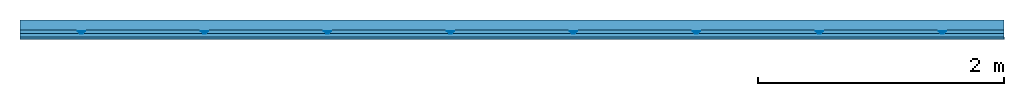
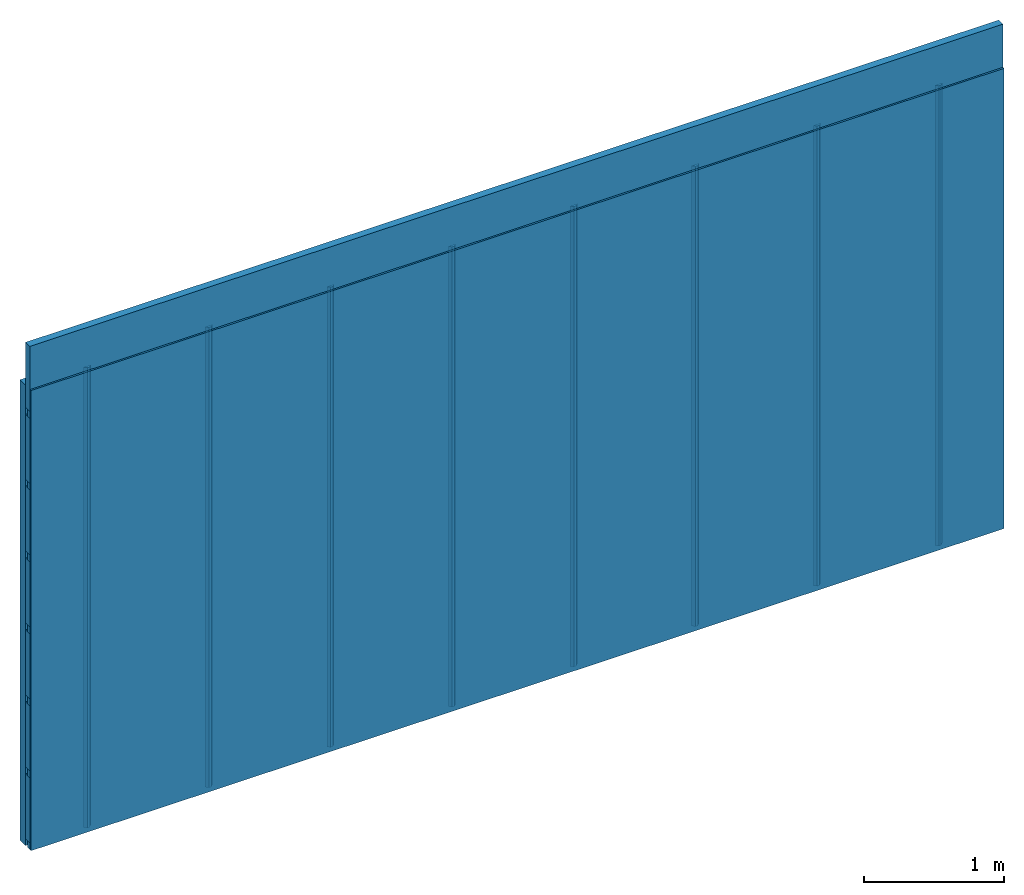
# One storey: 4 members, 1 plate, 1 element without a shape of its own.
"""IFC4 building model written with IfcOpenShell, lengths in metres."""

import ifcopenshell
import ifcopenshell.guid

model = None  # the IFC model being written
_history = None  # IfcOwnerHistory: only IFC2X3 demands one
_inside = {}  # id of a spatial element -> (the spatial element, [elements in it])
_under = {}  # id of a project, library or spatial element -> (it, [spatial elements below it])
_declared = {}  # id of a project -> (the project, [libraries it declares])
_typed = {}  # id of a type object -> (the type object, [elements of that type])
_made_of = {}  # id of a material, layer set ... -> (it, [elements and type objects made of it])


def new_model(schema):
    """Start an empty IFC model of exactly this schema.

    Asked for "IFC4X3", IfcOpenShell would pick the latest addendum, in which some entities
    have other attributes; the version numbers below select the first issue.
    IFC2X3 requires an IfcOwnerHistory on every rooted entity: one is made here for all.
    """
    global model, _history
    if schema == "IFC4X3":
        model = ifcopenshell.file(schema_version=(4, 3, 0, 0))
    else:
        model = ifcopenshell.file(schema=schema)
    _inside.clear()
    _under.clear()
    _declared.clear()
    _typed.clear()
    _made_of.clear()
    _history = None
    if model.schema == "IFC2X3":
        org = make("IfcOrganization", Name="unknown")
        user = make(
            "IfcPersonAndOrganization",
            ThePerson=make("IfcPerson", FamilyName="unknown"),
            TheOrganization=org,
        )
        app = make(
            "IfcApplication",
            ApplicationDeveloper=org,
            Version="unknown",
            ApplicationFullName="unknown",
            ApplicationIdentifier="unknown",
        )
        _history = make(
            "IfcOwnerHistory",
            OwningUser=user,
            OwningApplication=app,
            ChangeAction="ADDED",
            CreationDate=0,
        )
    return model


def make(cls, **values):
    """One entity of the class cls with the attributes given. An attribute that is None is left unset."""
    return model.create_entity(
        cls, **{name: value for name, value in values.items() if value is not None}
    )


def rooted(cls, **values):
    """An entity with a GlobalId (a new one), such as an element, a storey or a relation."""
    return make(cls, GlobalId=ifcopenshell.guid.new(), OwnerHistory=_history, **values)


def si_unit(unit_type, name, prefix=None):
    """IfcSIUnit, for example si_unit("LENGTHUNIT", "METRE", prefix="MILLI")."""
    return make("IfcSIUnit", UnitType=unit_type, Prefix=prefix, Name=name)


def derived_unit(unit_type, elements):
    """IfcDerivedUnit: a product of units, each with its exponent."""
    return make(
        "IfcDerivedUnit",
        Elements=[
            make("IfcDerivedUnitElement", Unit=unit, Exponent=power)
            for unit, power in elements
        ],
        UnitType=unit_type,
    )


def assignment(units):
    """IfcUnitAssignment: the units of a project."""
    return None if units is None else make("IfcUnitAssignment", Units=units)


def point(xyz):
    """IfcCartesianPoint."""
    return None if xyz is None else make("IfcCartesianPoint", Coordinates=xyz)


def direction(xyz):
    """IfcDirection."""
    return None if xyz is None else make("IfcDirection", DirectionRatios=xyz)


def frame(location, z_axis=None, x_axis=None):
    """IfcAxis2Placement3D, a coordinate frame: its origin and axes. An axis left out is left unset."""
    return make(
        "IfcAxis2Placement3D",
        Location=point(location),
        Axis=direction(z_axis),
        RefDirection=direction(x_axis),
    )


def frame_2d(location, x_axis=None):
    """IfcAxis2Placement2D, a coordinate frame in the plane: its origin and x axis."""
    return make(
        "IfcAxis2Placement2D", Location=point(location), RefDirection=direction(x_axis)
    )


def origin():
    """The frame at (0, 0, 0) with its axes left unset."""
    return frame((0.0, 0.0, 0.0))


def place(relative_to, where):
    """IfcLocalPlacement: puts the frame where relative to a parent placement (None: the world)."""
    return make(
        "IfcLocalPlacement", PlacementRelTo=relative_to, RelativePlacement=where
    )


def context(
    kind, dimensions, precision=None, world=None, true_north=None, identifier=None
):
    """IfcGeometricRepresentationContext, for example the 3D "Model" context."""
    return make(
        "IfcGeometricRepresentationContext",
        ContextIdentifier=identifier,
        ContextType=kind,
        CoordinateSpaceDimension=dimensions,
        Precision=precision,
        WorldCoordinateSystem=world,
        TrueNorth=true_north,
    )


def project(units=None, contexts=None):
    """IfcProject with its units and contexts."""
    return rooted(
        "IfcProject",
        Name="project",
        RepresentationContexts=contexts,
        UnitsInContext=assignment(units),
    )


def spatial(cls, under=None, at=None, **own):
    """A site, building, storey or space (cls), placed at a placement, below another one or the project."""
    s = rooted(cls, ObjectPlacement=at, **own)
    if under is not None:
        _under.setdefault(under.id(), (under, []))[1].append(s)
    return s


def polyline(points):
    """IfcPolyline through the points."""
    return make("IfcPolyline", Points=[point(p) for p in points])


def profile(cls, at=None, kind="AREA", **sizes):
    """A parametric profile (cls). Its sizes go by their IFC names, for example OverallWidth=200.0."""
    return make(cls, ProfileType=kind, Position=at, **sizes)


def rectangle(**sizes):
    """IfcRectangleProfileDef."""
    return profile("IfcRectangleProfileDef", **sizes)


def outline(outer, holes=None, kind="AREA"):
    """IfcArbitraryClosedProfileDef: a profile drawn as a closed curve; with holes, ...WithVoids."""
    if holes is None:
        return make("IfcArbitraryClosedProfileDef", ProfileType=kind, OuterCurve=outer)
    return make(
        "IfcArbitraryProfileDefWithVoids",
        ProfileType=kind,
        OuterCurve=outer,
        InnerCurves=holes,
    )


def extrude(swept, where, along, depth):
    """IfcExtrudedAreaSolid: the profile swept, set in the frame where, extruded along a direction by depth."""
    return make(
        "IfcExtrudedAreaSolid",
        SweptArea=swept,
        Position=where,
        ExtrudedDirection=direction(along),
        Depth=depth,
    )


def shape(context_of_items, identifier, shape_type, items):
    """IfcShapeRepresentation: the items that make up one representation, for example the "Body"."""
    return make(
        "IfcShapeRepresentation",
        ContextOfItems=context_of_items,
        RepresentationIdentifier=identifier,
        RepresentationType=shape_type,
        Items=items,
    )


def material(Name=None, Category=None):
    """IfcMaterial."""
    return make("IfcMaterial", Name=Name, Category=Category)


def layer(
    of_material, thickness, ventilated=None, Name=None, Category=None, Priority=None
):
    """IfcMaterialLayer: one layer of a wall or slab, of a material (None: an air gap)."""
    return make(
        "IfcMaterialLayer",
        Material=of_material,
        LayerThickness=thickness,
        IsVentilated=ventilated,
        Name=Name,
        Category=Category,
        Priority=Priority,
    )


def layer_set(layers, Name=None):
    """IfcMaterialLayerSet."""
    return make("IfcMaterialLayerSet", MaterialLayers=layers, LayerSetName=Name)


def made_of(thing, what):
    """Note that an element or type object is made of a material, layer set ...; save() writes the relation."""
    if what is not None:
        _made_of.setdefault(what.id(), (what, []))[1].append(thing)
    return thing


def type_object(cls, material=None, **own):
    """A type object (cls), such as IfcWallType, which elements share."""
    return made_of(rooted(cls, **own), material)


def element(
    cls,
    number,
    at=None,
    inside=None,
    cuts=None,
    type_object=None,
    material=None,
    context=None,
    identifier="Body",
    shape_type=None,
    held_by="IfcProductDefinitionShape",
    body=None,
    shapes=None,
    **own,
):
    """One element of the class cls, such as IfcWall. Its Tag is "e" and its number.

    at: its placement. inside: the storey or other place that contains it. cuts: it is an
    opening in that element (IfcRelVoidsElement). A single representation is given by context,
    identifier, shape_type and body (its items); several are given by shapes. held_by: the class
    of the entity that holds the representations. save() writes the other relations.
    """
    e = rooted(cls, Tag="e%d" % number, ObjectPlacement=at, **own)
    if body is not None:
        shapes = [shape(context, identifier, shape_type, body)]
    if shapes is not None:
        e.Representation = make(held_by, Representations=shapes)
    if inside is not None:
        _inside.setdefault(inside.id(), (inside, []))[1].append(e)
    if cuts is not None:
        rooted(
            "IfcRelVoidsElement", RelatingBuildingElement=cuts, RelatedOpeningElement=e
        )
    if type_object is not None:
        _typed.setdefault(type_object.id(), (type_object, []))[1].append(e)
    return made_of(e, material)


def aggregate(whole, parts):
    """IfcRelAggregates: a whole, such as a stair, and the parts it consists of."""
    return rooted("IfcRelAggregates", RelatingObject=whole, RelatedObjects=parts)


def save(model, path):
    """Write the relations noted so far, then the file.

    IfcRelAggregates (storeys below a building ...), IfcRelContainedInSpatialStructure (elements
    in a storey), IfcRelDefinesByType, IfcRelAssociatesMaterial and IfcRelDeclares: one each for
    every whole, place, type object, material and project.
    """
    for whole, parts in _under.values():
        aggregate(whole, parts)
    for where, things in _inside.values():
        rooted(
            "IfcRelContainedInSpatialStructure",
            RelatedElements=things,
            RelatingStructure=where,
        )
    for kind, things in _typed.values():
        rooted("IfcRelDefinesByType", RelatedObjects=things, RelatingType=kind)
    for what, things in _made_of.values():
        rooted("IfcRelAssociatesMaterial", RelatedObjects=things, RelatingMaterial=what)
    for by, libraries in _declared.values():
        rooted("IfcRelDeclares", RelatingContext=by, RelatedDefinitions=libraries)
    model.write(path)


model = new_model("IFC4")

# Units and contexts
plan_context = context("Plan", 3, precision=1e-05, world=origin(), true_north=direction((0.0, 1.0)))
model_context = context("Model", 3, precision=1e-05, world=origin(), true_north=direction((0.0, 1.0)))
ifc_project = project(units=[si_unit("LENGTHUNIT", "METRE"), derived_unit("SOUNDPRESSUREUNIT", [(si_unit("PRESSUREUNIT", "PASCAL", prefix="MICRO"), 0)]), si_unit("ENERGYUNIT", "JOULE", prefix="MEGA"), si_unit("MASSUNIT", "GRAM", prefix="KILO"), derived_unit("THERMALTRANSMITTANCEUNIT", [(si_unit("POWERUNIT", "WATT"), 1), (si_unit("AREAUNIT", "SQUARE_METRE"), -1), (si_unit("THERMODYNAMICTEMPERATUREUNIT", "KELVIN"), -1)]), derived_unit("AREADENSITYUNIT", [(si_unit("MASSUNIT", "GRAM", prefix="KILO"), 1), (si_unit("AREAUNIT", "SQUARE_METRE"), -1)]), derived_unit("USERDEFINED", [(si_unit("ENERGYUNIT", "JOULE", prefix="MEGA"), 1), (si_unit("AREAUNIT", "SQUARE_METRE"), -1)])], contexts=[plan_context, model_context])

# Site, building, storey
site = spatial("IfcSite", under=ifc_project)
building_placement = place(None, origin())
building = spatial("IfcBuilding", under=site, at=building_placement)
storey_placement = place(building_placement, origin())
storey = spatial("IfcBuildingStorey", under=building, at=storey_placement)

# Wall, members, plate
ifc_layer_1 = layer(None, 0.08, Name="Support")
ifc_material_1 = material(Name="no composite action")
ifc_layer_2 = layer(ifc_material_1, 0.0, Name="Bond")
ifc_layer_3 = layer(None, 0.03, Name="Coupling")
ifc_layer_4 = layer(None, 0.03, Name="Battens / profiles")
ifc_material_2 = material(Name="Plasterboard type A", Category="03.008")
ifc_layer_5 = layer(ifc_material_2, 0.015, Name="Covering 1st layer")
ifc_material_3 = material(Name="joints", Category="04.017")
ifc_layer_6 = layer(ifc_material_3, 0.0, Name="Surface")
ifc_layer_set = layer_set([ifc_layer_1, ifc_layer_2, ifc_layer_3, ifc_layer_4, ifc_layer_5, ifc_layer_6])
wall_type = type_object("IfcWallType", Name="C0102", PredefinedType="NOTDEFINED", material=ifc_layer_set)
wall_placement = place(None, frame((0.0, 0.0, 0.0), z_axis=(0.0, -1.0, 0.0), x_axis=(1.0, 0.0, 0.0)))
wall = element("IfcWall", 1, at=wall_placement, inside=storey, type_object=wall_type, material=ifc_layer_set, Name="Wall #1")
ifc_material_4 = material()
member_1_placement = place(wall_placement, origin())
member_1 = element("IfcMember", 2, at=member_1_placement, material=ifc_material_4, Name="Support", context=plan_context, shape_type="SweptSolid", body=[
    extrude(rectangle(XDim=1.0, YDim=0.08, at=frame_2d((0.5, 0.04), x_axis=(1.0, 0.0))), frame((0.0, 4.0, 0.0), z_axis=(0.0, -1.0, 0.0), x_axis=(1.0, 0.0, 0.0)), (0.0, 0.0, 1.0), 4.0),
    extrude(rectangle(XDim=1.0, YDim=0.08, at=frame_2d((0.5, 0.04), x_axis=(1.0, 0.0))), frame((1.0, 4.0, 0.0), z_axis=(0.0, -1.0, 0.0), x_axis=(1.0, 0.0, 0.0)), (0.0, 0.0, 1.0), 4.0),
    extrude(rectangle(XDim=1.0, YDim=0.08, at=frame_2d((0.5, 0.04), x_axis=(1.0, 0.0))), frame((2.0, 4.0, 0.0), z_axis=(0.0, -1.0, 0.0), x_axis=(1.0, 0.0, 0.0)), (0.0, 0.0, 1.0), 4.0),
    extrude(rectangle(XDim=1.0, YDim=0.08, at=frame_2d((0.5, 0.04), x_axis=(1.0, 0.0))), frame((3.0, 4.0, 0.0), z_axis=(0.0, -1.0, 0.0), x_axis=(1.0, 0.0, 0.0)), (0.0, 0.0, 1.0), 4.0),
    extrude(rectangle(XDim=1.0, YDim=0.08, at=frame_2d((0.5, 0.04), x_axis=(1.0, 0.0))), frame((4.0, 4.0, 0.0), z_axis=(0.0, -1.0, 0.0), x_axis=(1.0, 0.0, 0.0)), (0.0, 0.0, 1.0), 4.0),
    extrude(rectangle(XDim=1.0, YDim=0.08, at=frame_2d((0.5, 0.04), x_axis=(1.0, 0.0))), frame((5.0, 4.0, 0.0), z_axis=(0.0, -1.0, 0.0), x_axis=(1.0, 0.0, 0.0)), (0.0, 0.0, 1.0), 4.0),
    extrude(rectangle(XDim=1.0, YDim=0.08, at=frame_2d((0.5, 0.04), x_axis=(1.0, 0.0))), frame((6.0, 4.0, 0.0), z_axis=(0.0, -1.0, 0.0), x_axis=(1.0, 0.0, 0.0)), (0.0, 0.0, 1.0), 4.0),
    extrude(rectangle(XDim=1.0, YDim=0.08, at=frame_2d((0.5, 0.04), x_axis=(1.0, 0.0))), frame((7.0, 4.0, 0.0), z_axis=(0.0, -1.0, 0.0), x_axis=(1.0, 0.0, 0.0)), (0.0, 0.0, 1.0), 4.0),
])
ifc_material_5 = material()
member_2_placement = place(wall_placement, origin())
member_2 = element("IfcMember", 3, at=member_2_placement, material=ifc_material_5, Name="Coupling", context=plan_context, shape_type="SweptSolid", body=[
    extrude(outline(polyline([(0.0, 0.0), (0.06, 0.0), (0.04, 0.02), (0.02, 0.02), (0.0, 0.0)])), frame((0.47, 4.0, 0.09), z_axis=(0.0, -1.0, 0.0), x_axis=(1.0, 0.0, 0.0)), (0.0, 0.0, 1.0), 4.0),
    extrude(outline(polyline([(0.0, 0.0), (0.06, 0.0), (0.04, 0.02), (0.02, 0.02), (0.0, 0.0)])), frame((1.47, 4.0, 0.09), z_axis=(0.0, -1.0, 0.0), x_axis=(1.0, 0.0, 0.0)), (0.0, 0.0, 1.0), 4.0),
    extrude(outline(polyline([(0.0, 0.0), (0.06, 0.0), (0.04, 0.02), (0.02, 0.02), (0.0, 0.0)])), frame((2.47, 4.0, 0.09), z_axis=(0.0, -1.0, 0.0), x_axis=(1.0, 0.0, 0.0)), (0.0, 0.0, 1.0), 4.0),
    extrude(outline(polyline([(0.0, 0.0), (0.06, 0.0), (0.04, 0.02), (0.02, 0.02), (0.0, 0.0)])), frame((3.47, 4.0, 0.09), z_axis=(0.0, -1.0, 0.0), x_axis=(1.0, 0.0, 0.0)), (0.0, 0.0, 1.0), 4.0),
    extrude(outline(polyline([(0.0, 0.0), (0.06, 0.0), (0.04, 0.02), (0.02, 0.02), (0.0, 0.0)])), frame((4.47, 4.0, 0.09), z_axis=(0.0, -1.0, 0.0), x_axis=(1.0, 0.0, 0.0)), (0.0, 0.0, 1.0), 4.0),
    extrude(outline(polyline([(0.0, 0.0), (0.06, 0.0), (0.04, 0.02), (0.02, 0.02), (0.0, 0.0)])), frame((5.47, 4.0, 0.09), z_axis=(0.0, -1.0, 0.0), x_axis=(1.0, 0.0, 0.0)), (0.0, 0.0, 1.0), 4.0),
    extrude(outline(polyline([(0.0, 0.0), (0.06, 0.0), (0.04, 0.02), (0.02, 0.02), (0.0, 0.0)])), frame((6.47, 4.0, 0.09), z_axis=(0.0, -1.0, 0.0), x_axis=(1.0, 0.0, 0.0)), (0.0, 0.0, 1.0), 4.0),
    extrude(outline(polyline([(0.0, 0.0), (0.06, 0.0), (0.04, 0.02), (0.02, 0.02), (0.0, 0.0)])), frame((7.47, 4.0, 0.09), z_axis=(0.0, -1.0, 0.0), x_axis=(1.0, 0.0, 0.0)), (0.0, 0.0, 1.0), 4.0),
])
member_3_placement = place(wall_placement, origin())
member_3 = element("IfcMember", 4, at=member_3_placement, material=ifc_material_5, Name="Battens / profiles", context=plan_context, shape_type="SweptSolid", body=[
    extrude(rectangle(XDim=0.06, YDim=0.03, at=frame_2d((0.03, 0.015), x_axis=(1.0, 0.0))), frame((0.0, 0.0, 0.11), z_axis=(1.0, 0.0, 0.0), x_axis=(0.0, 1.0, 0.0)), (0.0, 0.0, 1.0), 8.0),
    extrude(rectangle(XDim=0.06, YDim=0.03, at=frame_2d((0.03, 0.015), x_axis=(1.0, 0.0))), frame((0.0, 0.625, 0.11), z_axis=(1.0, 0.0, 0.0), x_axis=(0.0, 1.0, 0.0)), (0.0, 0.0, 1.0), 8.0),
    extrude(rectangle(XDim=0.06, YDim=0.03, at=frame_2d((0.03, 0.015), x_axis=(1.0, 0.0))), frame((0.0, 1.25, 0.11), z_axis=(1.0, 0.0, 0.0), x_axis=(0.0, 1.0, 0.0)), (0.0, 0.0, 1.0), 8.0),
    extrude(rectangle(XDim=0.06, YDim=0.03, at=frame_2d((0.03, 0.015), x_axis=(1.0, 0.0))), frame((0.0, 1.875, 0.11), z_axis=(1.0, 0.0, 0.0), x_axis=(0.0, 1.0, 0.0)), (0.0, 0.0, 1.0), 8.0),
    extrude(rectangle(XDim=0.06, YDim=0.03, at=frame_2d((0.03, 0.015), x_axis=(1.0, 0.0))), frame((0.0, 2.5, 0.11), z_axis=(1.0, 0.0, 0.0), x_axis=(0.0, 1.0, 0.0)), (0.0, 0.0, 1.0), 8.0),
    extrude(rectangle(XDim=0.06, YDim=0.03, at=frame_2d((0.03, 0.015), x_axis=(1.0, 0.0))), frame((0.0, 3.125, 0.11), z_axis=(1.0, 0.0, 0.0), x_axis=(0.0, 1.0, 0.0)), (0.0, 0.0, 1.0), 8.0),
    extrude(rectangle(XDim=0.06, YDim=0.03, at=frame_2d((0.03, 0.015), x_axis=(1.0, 0.0))), frame((0.0, 3.75, 0.11), z_axis=(1.0, 0.0, 0.0), x_axis=(0.0, 1.0, 0.0)), (0.0, 0.0, 1.0), 8.0),
])
ifc_material_6 = material()
member_4_placement = place(wall_placement, origin())
member_4 = element("IfcMember", 5, at=member_4_placement, material=ifc_material_6, Name="Cavity", context=plan_context, shape_type="SweptSolid", body=[
    extrude(rectangle(XDim=0.565, YDim=0.06, at=frame_2d((0.2825, 0.03), x_axis=(1.0, 0.0))), frame((0.0, 0.06, 0.08), z_axis=(1.0, 0.0, 0.0), x_axis=(0.0, 1.0, 0.0)), (0.0, 0.0, 1.0), 8.0),
    extrude(rectangle(XDim=0.565, YDim=0.06, at=frame_2d((0.2825, 0.03), x_axis=(1.0, 0.0))), frame((0.0, 0.685, 0.08), z_axis=(1.0, 0.0, 0.0), x_axis=(0.0, 1.0, 0.0)), (0.0, 0.0, 1.0), 8.0),
    extrude(rectangle(XDim=0.565, YDim=0.06, at=frame_2d((0.2825, 0.03), x_axis=(1.0, 0.0))), frame((0.0, 1.31, 0.08), z_axis=(1.0, 0.0, 0.0), x_axis=(0.0, 1.0, 0.0)), (0.0, 0.0, 1.0), 8.0),
    extrude(rectangle(XDim=0.565, YDim=0.06, at=frame_2d((0.2825, 0.03), x_axis=(1.0, 0.0))), frame((0.0, 1.935, 0.08), z_axis=(1.0, 0.0, 0.0), x_axis=(0.0, 1.0, 0.0)), (0.0, 0.0, 1.0), 8.0),
    extrude(rectangle(XDim=0.565, YDim=0.06, at=frame_2d((0.2825, 0.03), x_axis=(1.0, 0.0))), frame((0.0, 2.56, 0.08), z_axis=(1.0, 0.0, 0.0), x_axis=(0.0, 1.0, 0.0)), (0.0, 0.0, 1.0), 8.0),
    extrude(rectangle(XDim=0.565, YDim=0.06, at=frame_2d((0.2825, 0.03), x_axis=(1.0, 0.0))), frame((0.0, 3.185, 0.08), z_axis=(1.0, 0.0, 0.0), x_axis=(0.0, 1.0, 0.0)), (0.0, 0.0, 1.0), 8.0),
    extrude(rectangle(XDim=0.565, YDim=0.06, at=frame_2d((0.2825, 0.03), x_axis=(1.0, 0.0))), frame((0.0, 3.81, 0.08), z_axis=(1.0, 0.0, 0.0), x_axis=(0.0, 1.0, 0.0)), (0.0, 0.0, 1.0), 8.0),
])
plate_placement = place(wall_placement, origin())
plate = element("IfcPlate", 6, at=plate_placement, material=ifc_material_2, Name="Covering 1st layer", context=plan_context, shape_type="SweptSolid", body=[
    extrude(rectangle(XDim=8.0, YDim=4.0, at=frame_2d((4.0, 2.0), x_axis=(1.0, 0.0))), frame((0.0, 0.0, 0.14), z_axis=(0.0, 0.0, 1.0), x_axis=(1.0, 0.0, 0.0)), (0.0, 0.0, 1.0), 0.015),
])
aggregate(wall, [member_1, member_2, member_3, member_4, plate])

save(model, "model.ifc")
